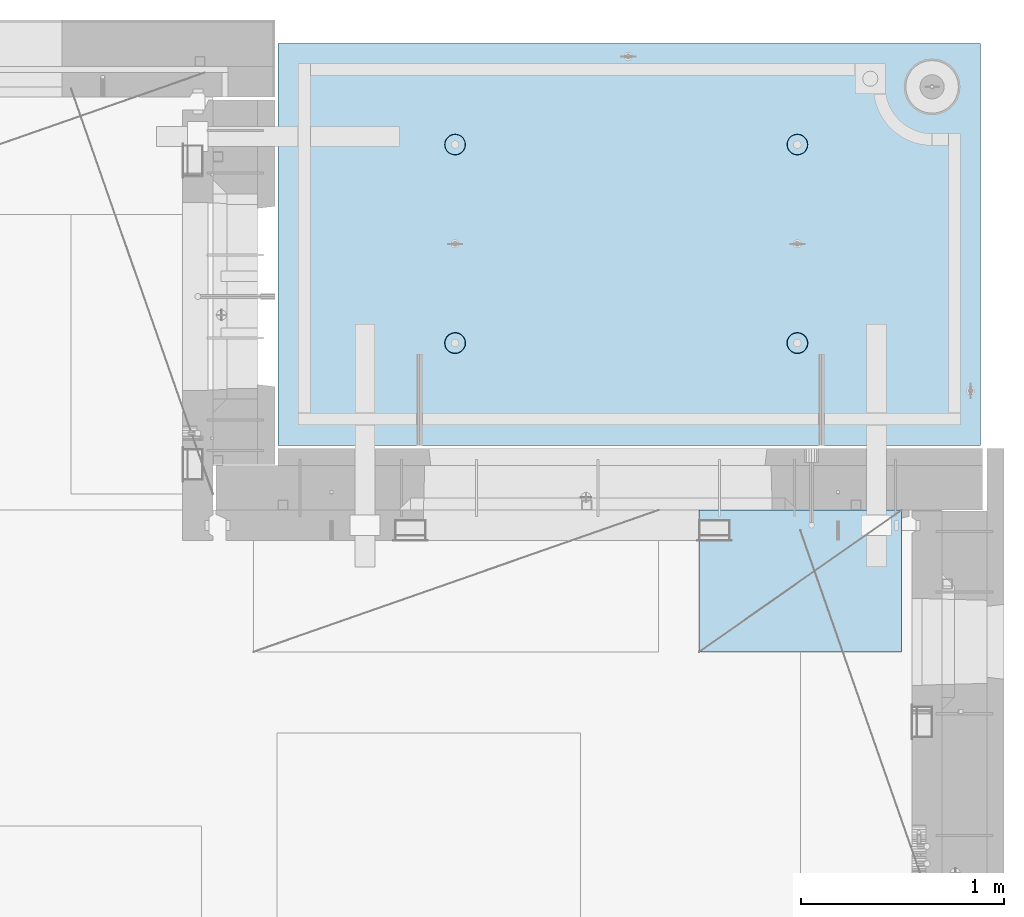
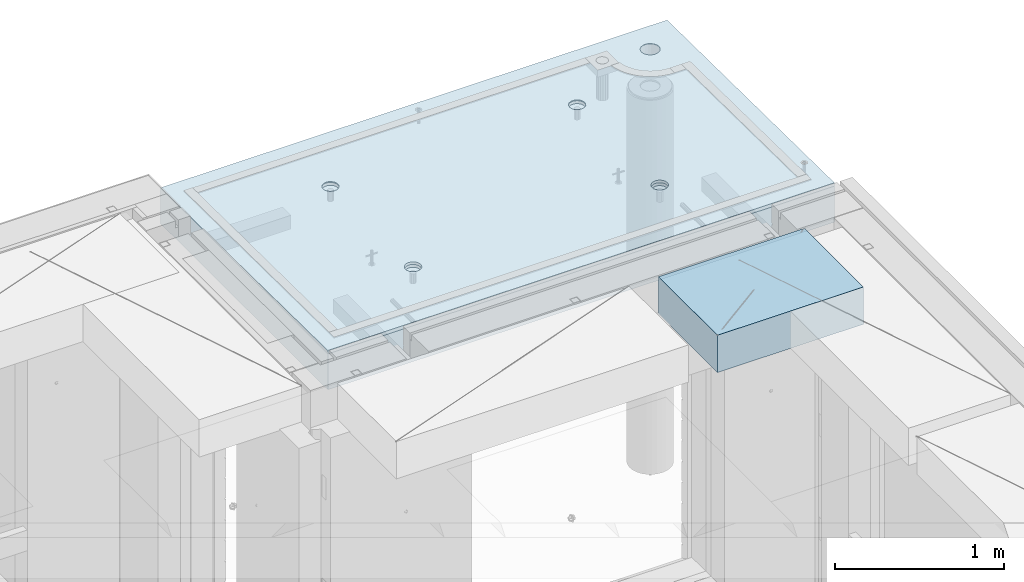
# One storey, part 202 of 334: 2 slabs, 1 plate, 2 elements without a shape of their own.
"""IFC2X3 building model written with IfcOpenShell, lengths in millimetres."""

from ifc_helpers import new_model, si_unit, frame, origin_with_axes, place, context, subcontext, project, spatial, faceted_brep, material, type_object, element, aggregate, save


model = new_model("IFC2X3")

# Units and contexts
model_context = context("Model", 3, precision=1e-05, world=origin_with_axes())
body_context = subcontext(model_context, "Body", "Model", "MODEL_VIEW")
ifc_project = project(units=[si_unit("LENGTHUNIT", "METRE", prefix="MILLI"), si_unit("AREAUNIT", "SQUARE_METRE"), si_unit("VOLUMEUNIT", "CUBIC_METRE"), si_unit("MASSUNIT", "GRAM", prefix="KILO"), si_unit("TIMEUNIT", "SECOND"), si_unit("PLANEANGLEUNIT", "RADIAN"), si_unit("SOLIDANGLEUNIT", "STERADIAN"), si_unit("THERMODYNAMICTEMPERATUREUNIT", "DEGREE_CELSIUS"), si_unit("LUMINOUSINTENSITYUNIT", "LUMEN")], contexts=[model_context])

# Site, building, storey
site_placement = place(None, origin_with_axes())
site = spatial("IfcSite", under=ifc_project, at=site_placement, CompositionType="ELEMENT")
building_placement = place(site_placement, origin_with_axes())
building = spatial("IfcBuilding", under=site, at=building_placement, CompositionType="ELEMENT")
storey_placement = place(building_placement, origin_with_axes())
storey = spatial("IfcBuildingStorey", under=building, at=storey_placement, Name="3", CompositionType="ELEMENT", Elevation=0.0)

# Assembly, slabs
assembly_1_placement = place(storey_placement, origin_with_axes())
assembly_1 = element("IfcElementAssembly", 1, at=assembly_1_placement, inside=storey, AssemblyPlace="NOTDEFINED", PredefinedType="REINFORCEMENT_UNIT")
ifc_material_1 = material(Name="CONCRETE/C35/45")
slab_type_1 = type_object("IfcSlabType", PredefinedType="NOTDEFINED")
slab_1_placement = place(assembly_1_placement, frame((31779.9998568133, 20899.9965573523, 90717.5), z_axis=(0.0, 1.0, 0.0), x_axis=(1.0, 0.0, 0.0)))
slab_1 = element("IfcSlab", 2, at=slab_1_placement, type_object=slab_type_1, material=ifc_material_1, PredefinedType="FLOOR", context=body_context, shape_type="Brep", body=[
    faceted_brep([(3287.06232936882, 9.55874156874779, 1751.46731182328), (3287.06232936882, 12.4999999999563, 1751.46731182328), (3278.5399580536, 12.4999999999563, 1734.74121634823), (3278.5399580536, 9.3480858430994, 1734.74121634823), (3265.26605352866, 12.4999999999563, 1721.46731182328), (3265.26605352866, 9.18090851265879, 1721.46731182328), (3248.5399580536, 12.4999999999563, 1712.94494050807), (3248.5399580536, 9.07357405936637, 1712.94494050807), (3229.99893839111, 12.4999999999563, 1710.00833148578), (3229.99893839111, 9.03658912732499, 1710.00833148578), (3211.45791872861, 12.4999999999563, 1712.94494050807), (3211.45791872861, 9.07357405936637, 1712.94494050807), (3194.73182325356, 12.4999999999563, 1721.46731182328), (3194.73182325356, 9.18090851267334, 1721.46731182328), (3181.45791872861, 12.4999999999563, 1734.74121634823), (3181.45791872861, 9.3480858430994, 1734.74121634823), (3172.9355474134, 12.4999999999563, 1751.46731182328), (3172.9355474134, 9.55874156874779, 1751.46731182328), (3169.99893839111, 12.4999999999563, 1770.00833148578), (3169.99893839111, 9.79225523948844, 1770.00833148578), (3172.9355474134, 12.4999999999563, 1788.54935114827), (3172.9355474134, 10.0257689102291, 1788.54935114827), (3181.45791872861, 12.4999999999563, 1805.27544662332), (3181.45791872861, 10.236424635892, 1805.27544662332), (3194.73182325356, 12.4999999999563, 1818.54935114827), (3194.73182325356, 10.4036019663181, 1818.54935114827), (3211.45791872861, 12.4999999999563, 1827.07172246349), (3211.45791872861, 10.5109364196105, 1827.07172246349), (3229.99893839111, 12.4999999999563, 1830.00833148578), (3229.99893839111, 10.5479213516664, 1830.00833148578), (3248.5399580536, 12.4999999999563, 1827.07172246349), (3248.5399580536, 10.5109364196105, 1827.07172246349), (3265.26605352866, 12.4999999999563, 1818.54935114827), (3265.26605352866, 10.4036019663181, 1818.54935114827), (3278.5399580536, 12.4999999999563, 1805.27544662332), (3278.5399580536, 10.2364246358775, 1805.27544662332), (3287.06232936882, 12.4999999999563, 1788.54935114827), (3287.06232936882, 10.0257689102291, 1788.54935114827), (3289.99893839111, 12.4999999999563, 1770.00833148578), (3289.99893839111, 9.79225523948844, 1770.00833148578), (7.41420080885291e-08, 12.4999999999927, 0.0), (-7.41420080885291e-08, -12.5, -3.63797880709171e-12), (0.0, 12.5, 1985.00366210938), (3470.0, 12.5, 0.0), (3470.00000000004, 12.4999999999563, 1985.00366210935), (3470.0, -12.5, 0.0), (2614.71871715545, -5.93617388149141, 521.168755308547), (2613.67503600632, 12.4999999999709, 520.829642746605), (2616.18047624359, 12.4999999999709, 505.010915653602), (2617.28998057371, -6.13967274603783, 505.010915653602), (2607.28293696061, -5.7526757610467, 535.738532951145), (2606.40396524136, 12.4999999999709, 535.099922616191), (2595.7125242481, -5.60710538028798, 547.296842506817), (2595.0790070157, 12.4999999999709, 546.424880841845), (2581.14006820649, -5.51366887726181, 554.715714533479), (2580.80872714612, 12.4999999999709, 553.695951606805), (2564.99000005311, -5.48147745869937, 557.271717883286), (2564.99000005311, 12.4999999999709, 556.201391844079), (2548.83993189974, -5.51366887726181, 554.715714533479), (2549.17127296011, 12.4999999999709, 553.695951606805), (2534.26747585813, -5.60710538028798, 547.296842506817), (2534.90099309052, 12.4999999999709, 546.424880841845), (2522.69706314561, -5.75267576103215, 535.738532951145), (2523.57603486487, 12.4999999999709, 535.099922616191), (2515.26128295077, -5.93617388147686, 521.168755308547), (2516.30496409991, 12.4999999999709, 520.829642746605), (2512.69001953251, -6.13967274603783, 505.010915653602), (2513.79952386263, 12.4999999999709, 505.010915653602), (2515.23823726424, -6.34326591769059, 488.84558800119), (2516.30496409991, 12.4999999999709, 489.192188560599), (2522.65977443627, -6.52701093736687, 474.256206522903), (2523.57603486487, 12.4999999999709, 474.921908691009), (2534.2301871423, -6.67288650246337, 462.673665286093), (2534.90099309052, 12.4999999999709, 463.596950465359), (2548.81688620273, -6.76656990486663, 455.235189411429), (2549.17127296011, 12.4999999999709, 456.325879700398), (2564.99000005311, -6.79885563062271, 452.67169805654), (2564.99000005311, 12.4999999999709, 453.820439463125), (2581.16311390349, -6.76656990486663, 455.235189411429), (2580.80872714612, 12.4999999999709, 456.325879700398), (2595.74981296392, -6.67288650246337, 462.673665286093), (2595.07900701571, 12.4999999999709, 463.596950465359), (2607.32022566996, -6.52701093736687, 474.256206522903), (2606.40396524136, 12.4999999999709, 474.921908691009), (2614.74176284199, -6.34326591769059, 488.84558800119), (2613.67503600632, 12.4999999999709, 489.192188560599), (924.718717121814, -5.93617388307757, 521.168755181017), (923.675035972585, 12.4999999999854, 520.829642619046), (926.180476209858, 12.4999999999854, 505.010915526043), (927.289980540074, -6.13967274762399, 505.010915526043), (917.282936926953, -5.75267576263286, 535.738532823641), (916.403965207624, 12.4999999999854, 535.099922488633), (905.712524214421, -5.60710538187413, 547.296842379335), (905.07900698197, 12.4999999999854, 546.424880714287), (891.140068172776, -5.51366887886252, 554.715714406011), (890.808727112384, 12.4999999999854, 553.695951479247), (874.990000019381, -5.48147746030008, 557.271717755822), (874.990000019381, 12.4999999999854, 556.20139171652), (858.839931865987, -5.51366887886252, 554.715714406011), (859.171272926378, 12.4999999999854, 553.695951479247), (844.267475824341, -5.60710538187413, 547.296842379335), (844.900993056792, 12.4999999999854, 546.424880714287), (832.697063111809, -5.75267576263286, 535.738532823641), (833.576034831138, 12.4999999999854, 535.099922488633), (825.261282916948, -5.93617388307757, 521.168755181017), (826.304964066177, 12.4999999999854, 520.829642619046), (822.690019498688, -6.13967274762399, 505.010915526043), (823.799523828904, 12.4999999999854, 505.010915526043), (825.238237230413, -6.34326591927675, 488.845587873602), (826.304964066174, 12.4999999999854, 489.19218843304), (832.659774402466, -6.52701093895303, 474.25620639529), (833.576034831141, 12.4999999999854, 474.921908563454), (844.230187108518, -6.67288650404953, 462.673665158458), (844.900993056788, 12.4999999999854, 463.5969503378), (858.816886168974, -6.76656990646734, 455.23518928378), (859.171272926378, 12.4999999999854, 456.32587957284), (874.990000019381, -6.79885563222342, 452.671697928887), (874.990000019381, 12.4999999999854, 453.820439335566), (891.163113869789, -6.76656990646734, 455.23518928378), (890.808727112384, 12.4999999999854, 456.32587957284), (905.749812930244, -6.67288650404953, 462.673665158458), (905.079006981974, 12.4999999999854, 463.5969503378), (917.320225636297, -6.52701093895303, 474.25620639529), (916.403965207621, 12.4999999999854, 474.921908563454), (924.741762808349, -6.34326591927675, 488.845587873602), (923.675035972588, 12.4999999999854, 489.19218843304), (924.02016693788, 6.4034111394576, 1500.93361352766), (923.67503595199, 12.4999999999854, 1500.82147367257), (926.18047618926, 12.4999999999854, 1485.00274657956), (926.555311256641, 6.20277086795249, 1485.00274657956), (916.688838773403, 6.58433162167785, 1515.29872631776), (916.403965187026, 12.4999999999854, 1515.09175354215), (905.280958178348, 6.7278571434581, 1526.69467377167), (905.079006961372, 12.4999999999854, 1526.4167117678), (890.913204613287, 6.81998112349538, 1534.0093312807), (890.808727091786, 12.4999999999854, 1533.68778253277), (874.989999998783, 6.85172034216521, 1536.52942989253), (874.989999998783, 12.4999999999854, 1536.19322277004), (859.066795384279, 6.81998112349538, 1534.0093312807), (859.17127290578, 12.4999999999854, 1533.68778253277), (844.699041819218, 6.7278571434581, 1526.69467377167), (844.900993036194, 12.4999999999854, 1526.4167117678), (833.291161224162, 6.58433162167785, 1515.29872631776), (833.57603481054, 12.4999999999854, 1515.09175354215), (825.959833059685, 6.4034111394576, 1500.93361352766), (826.304964045576, 12.4999999999854, 1500.82147367257), (823.424688740924, 6.20277086795249, 1485.00274657956), (823.799523808306, 12.4999999999854, 1485.00274657956), (825.93711110095, 6.00203761411831, 1469.06449681953), (826.304964045576, 12.4999999999854, 1469.18401948656), (833.254396317472, 5.82087370089721, 1454.68005557312), (833.57603481054, 12.4999999999854, 1454.91373961698), (844.66227690614, 5.67704728177341, 1443.26021682579), (844.90099303619, 12.4999999999854, 1443.58878139132), (859.044073415214, 5.58467987058975, 1435.9262308483), (859.17127290578, 12.4999999999854, 1436.31771062636), (874.989999998783, 5.55284766948898, 1433.39874941703), (874.989999998783, 12.4999999999854, 1433.81227038909), (890.935926582351, 5.58467987058975, 1435.9262308483), (890.808727091786, 12.4999999999854, 1436.31771062636), (905.317723091426, 5.67704728177341, 1443.26021682579), (905.079006961376, 12.4999999999854, 1443.58878139132), (916.725603680094, 5.82087370089721, 1454.68005557312), (916.403965187026, 12.4999999999854, 1454.91373961698), (924.042888896616, 6.00203761411831, 1469.06449681953), (923.67503595199, 12.4999999999854, 1469.18401948656), (2564.9899999698, 12.4999999999709, 1433.81227048016), (2564.9899999698, 5.55284767062403, 1433.39874950818), (2580.93592655335, 5.5846798717248, 1435.92623093945), (2580.8087270628, 12.4999999999709, 1436.31771071744), (2549.17127287679, 12.4999999999709, 1436.31771071744), (2549.04407338624, 5.5846798717248, 1435.92623093945), (2534.9009930072, 12.4999999999709, 1443.5887814824), (2534.66227687719, 5.67704728290846, 1443.26021691693), (2523.57603478155, 12.4999999999709, 1454.91373970805), (2523.25439628854, 5.82087370203226, 1454.68005566423), (2516.30496401659, 12.4999999999709, 1469.18401957764), (2515.93711107203, 6.00203761523881, 1469.06449691063), (2513.79952377931, 12.4999999999709, 1485.00274667064), (2513.424688712, 6.20277086908754, 1485.00274667064), (2516.30496401659, 12.4999999999709, 1500.82147376364), (2515.95983303076, 6.40341114059265, 1500.93361361872), (2523.57603478155, 12.4999999999709, 1515.09175363323), (2523.29116119523, 6.5843316228129, 1515.2987264088), (2534.90099300721, 12.4999999999709, 1526.41671185888), (2534.69904179027, 6.72785714459314, 1526.69467386269), (2549.17127287679, 12.4999999999709, 1533.68778262385), (2549.06679535531, 6.81998112463043, 1534.00933137171), (2564.9899999698, 12.4999999999709, 1536.19322286112), (2564.9899999698, 6.85172034330026, 1536.52942998354), (2580.8087270628, 12.4999999999709, 1533.68778262385), (2580.91320458428, 6.81998112463043, 1534.00933137171), (2595.07900693238, 12.4999999999709, 1526.41671185888), (2595.28095814932, 6.72785714459314, 1526.69467386269), (2606.40396515804, 12.4999999999709, 1515.09175363323), (2606.68883874436, 6.5843316228129, 1515.2987264088), (2613.675035923, 12.4999999999709, 1500.82147376364), (2614.02016690883, 6.40341114059265, 1500.93361361872), (2606.72560365105, 5.82087370203226, 1454.68005566423), (2595.3177230624, 5.67704728290846, 1443.26021691693), (2616.55531122759, 6.20277086908754, 1485.00274667064), (2614.04288886756, 6.00203761523881, 1469.06449691063), (2595.07900693239, 12.4999999999709, 1443.5887814824), (2606.40396515804, 12.4999999999709, 1454.91373970805), (2613.675035923, 12.4999999999709, 1469.18401957764), (2616.18047616028, 12.4999999999709, 1485.00274667064)], [[[0, 1, 2, 3]], [[3, 2, 4, 5]], [[5, 4, 6, 7]], [[7, 6, 8, 9]], [[9, 8, 10, 11]], [[11, 10, 12, 13]], [[13, 12, 14, 15]], [[15, 14, 16, 17]], [[17, 16, 18, 19]], [[19, 18, 20, 21]], [[21, 20, 22, 23]], [[23, 22, 24, 25]], [[25, 24, 26, 27]], [[27, 26, 28, 29]], [[29, 28, 30, 31]], [[31, 30, 32, 33]], [[33, 32, 34, 35]], [[35, 34, 36, 37]], [[37, 36, 38, 39]], [[39, 38, 1, 0]], [[40, 41, 42]], [[43, 44, 45]], [[40, 43, 45, 41]], [[46, 47, 48, 49]], [[50, 51, 47, 46]], [[52, 53, 51, 50]], [[54, 55, 53, 52]], [[56, 57, 55, 54]], [[58, 59, 57, 56]], [[59, 58, 60, 61]], [[61, 60, 62, 63]], [[63, 62, 64, 65]], [[65, 64, 66, 67]], [[67, 66, 68, 69]], [[69, 68, 70, 71]], [[71, 70, 72, 73]], [[73, 72, 74, 75]], [[75, 74, 76, 77]], [[78, 79, 77, 76]], [[80, 81, 79, 78]], [[82, 83, 81, 80]], [[84, 85, 83, 82]], [[49, 48, 85, 84]], [[86, 87, 88, 89]], [[90, 91, 87, 86]], [[92, 93, 91, 90]], [[94, 95, 93, 92]], [[96, 97, 95, 94]], [[98, 99, 97, 96]], [[99, 98, 100, 101]], [[101, 100, 102, 103]], [[103, 102, 104, 105]], [[105, 104, 106, 107]], [[107, 106, 108, 109]], [[109, 108, 110, 111]], [[111, 110, 112, 113]], [[113, 112, 114, 115]], [[115, 114, 116, 117]], [[118, 119, 117, 116]], [[120, 121, 119, 118]], [[122, 123, 121, 120]], [[124, 125, 123, 122]], [[89, 88, 125, 124]], [[126, 127, 128, 129]], [[130, 131, 127, 126]], [[132, 133, 131, 130]], [[134, 135, 133, 132]], [[136, 137, 135, 134]], [[138, 139, 137, 136]], [[140, 141, 139, 138]], [[142, 143, 141, 140]], [[143, 142, 144, 145]], [[145, 144, 146, 147]], [[147, 146, 148, 149]], [[149, 148, 150, 151]], [[151, 150, 152, 153]], [[153, 152, 154, 155]], [[155, 154, 156, 157]], [[157, 156, 158, 159]], [[159, 158, 160, 161]], [[162, 163, 161, 160]], [[164, 165, 163, 162]], [[129, 128, 165, 164]], [[166, 167, 168, 169]], [[170, 171, 167, 166]], [[172, 173, 171, 170]], [[174, 175, 173, 172]], [[176, 177, 175, 174]], [[178, 179, 177, 176]], [[180, 181, 179, 178]], [[182, 183, 181, 180]], [[183, 182, 184, 185]], [[185, 184, 186, 187]], [[187, 186, 188, 189]], [[189, 188, 190, 191]], [[191, 190, 192, 193]], [[193, 192, 194, 195]], [[195, 194, 196, 197]], [[44, 42, 41, 45], [3, 5, 7, 9, 11, 13, 15, 17, 19, 21, 23, 25, 27, 29, 31, 33, 35, 37, 39, 0], [198, 199, 168, 167, 171, 173, 175, 177, 179, 181, 183, 185, 187, 189, 191, 193, 195, 197, 200, 201], [162, 160, 158, 156, 154, 152, 150, 148, 146, 144, 142, 140, 138, 136, 134, 132, 130, 126, 129, 164], [122, 120, 118, 116, 114, 112, 110, 108, 106, 104, 102, 100, 98, 96, 94, 92, 90, 86, 89, 124], [82, 80, 78, 76, 74, 72, 70, 68, 66, 64, 62, 60, 58, 56, 54, 52, 50, 46, 49, 84]], [[169, 168, 199, 202]], [[198, 203, 202, 199]], [[201, 204, 203, 198]], [[200, 205, 204, 201]], [[197, 196, 205, 200]], [[43, 40, 42, 44], [34, 32, 30, 28, 26, 24, 22, 20, 18, 16, 14, 12, 10, 8, 6, 4, 2, 1, 38, 36], [194, 192, 190, 188, 186, 184, 182, 180, 178, 176, 174, 172, 170, 166, 169, 202, 203, 204, 205, 196], [131, 133, 135, 137, 139, 141, 143, 145, 147, 149, 151, 153, 155, 157, 159, 161, 163, 165, 128, 127], [91, 93, 95, 97, 99, 101, 103, 105, 107, 109, 111, 113, 115, 117, 119, 121, 123, 125, 88, 87], [51, 53, 55, 57, 59, 61, 63, 65, 67, 69, 71, 73, 75, 77, 79, 81, 83, 85, 48, 47]]]),
])
slab_type_2 = type_object("IfcSlabType", PredefinedType="NOTDEFINED")
slab_2_placement = place(assembly_1_placement, frame((31779.9998568132, 20899.9965573523, 90575.0), z_axis=(-1.19799915409591e-06, 0.999999999999282, 0.0), x_axis=(0.999999999999282, 1.19800000174933e-06, 0.0)))
slab_2 = element("IfcSlab", 3, at=slab_2_placement, type_object=slab_type_2, material=ifc_material_1, PredefinedType="FLOOR", context=body_context, shape_type="Brep", body=[
    faceted_brep([(2959.65048069304, -130.0, 1795.81551698422), (2959.65048069304, 130.000000000015, 1795.81551698422), (2951.52269537287, 130.000000000015, 1783.6488444481), (2951.52269537287, -130.0, 1783.6488444481), (2939.35761686434, 130.000000000015, 1775.51867349706), (2939.35761686434, -130.0, 1775.51867349706), (2925.00726809365, 130.000000000015, 1772.66274895821), (2925.00726809365, -130.0, 1772.66274895821), (2910.65635957491, 130.000000000015, 1775.51585945357), (2910.65635957491, -130.0, 1775.51585945357), (2898.48968703879, 130.000000000015, 1783.64364477374), (2898.48968703879, -130.0, 1783.64364477374), (2890.35951608775, 130.000000000015, 1795.80872328227), (2890.35951608775, -130.0, 1795.80872328227), (2887.5035915489, 130.000000000015, 1810.15907205296), (2887.5035915489, -130.0, 1810.15907205296), (2890.35670204427, 130.000000000015, 1824.5099805717), (2890.35670204427, -130.0, 1824.5099805717), (2898.48448736444, 130.000000000015, 1836.67665310783), (2898.48448736444, -130.0, 1836.67665310783), (2910.64956587296, 130.000000000015, 1844.80682405887), (2910.64956587296, -130.0, 1844.80682405887), (2924.99991464366, 130.000000000015, 1847.66274859772), (2924.99991464366, -130.0, 1847.66274859772), (2939.3508231624, 130.000000000015, 1844.80963810235), (2939.3508231624, -130.0, 1844.80963810235), (2951.51749569851, 130.000000000015, 1836.68185278219), (2951.51749569851, -130.0, 1836.68185278219), (2959.64766664955, 130.000000000015, 1824.51677427365), (2959.64766664955, -130.0, 1824.51677427365), (2962.50359118841, 130.000000000015, 1810.16642550296), (2962.50359118841, -130.0, 1810.16642550296), (3470.0, -130.0, -2.20097717829049e-09), (0.0, -130.0, -3.63797880709171e-12), (0.0, 130.0, -1.81898940354586e-12), (3470.0, 130.0, -2.20097717829049e-09), (3470.00048828125, -130.0, 1985.00366210938), (3470.00048828125, 130.0, 1985.00366210938), (0.000559809086553287, -130.0, 1985.00366210938), (0.000559809086553287, 130.0, 1985.00366210938), (890.443701616427, -110.0, 1437.44815412734), (904.382128602592, -110.0, 1444.55010256952), (915.443737652884, -110.0, 1455.61166772744), (922.54574140269, -110.0, 1469.55006653296), (924.992946242415, -110.0, 1485.00091139648), (922.545802711662, -110.0, 1500.4517659704), (915.443854269477, -110.0, 1514.39019295657), (904.382289111563, -110.0, 1525.45180200686), (890.44389030604, -110.0, 1532.55380575666), (874.993045442512, -110.0, 1535.00101059639), (859.5421908686, -110.0, 1532.55386706564), (845.603763882435, -110.0, 1525.45191862345), (834.542154832139, -110.0, 1514.39035346554), (827.440151082337, -110.0, 1500.45195466001), (824.992946242612, -110.0, 1485.00110979649), (827.440089773365, -110.0, 1469.55025522257), (834.542038215546, -110.0, 1455.61182823641), (845.603603373464, -110.0, 1444.55021918611), (859.542002178987, -110.0, 1437.44821543631), (874.992847042511, -110.0, 1435.00101059658), (923.678013579975, -130.0, 1500.81964109834), (926.183422432889, -130.0, 1485.00090903458), (916.406971127264, -130.0, 1515.08993539371), (905.082035370349, -130.0, 1526.41491608806), (890.811769926597, -130.0, 1533.68601516524), (874.993047804415, -130.0, 1536.19148678686), (859.174315740653, -130.0, 1533.68607793395), (844.904021445287, -130.0, 1526.41503548124), (833.579040750941, -130.0, 1515.09009972432), (826.307941673756, -130.0, 1500.81983428057), (823.802470052138, -130.0, 1485.00111215839), (826.307878905049, -130.0, 1469.18238009463), (833.578921357763, -130.0, 1454.91208579926), (844.903857114674, -130.0, 1443.58710510491), (859.17412255843, -130.0, 1436.31600602773), (874.992844680608, -130.0, 1433.81053440611), (890.811576744374, -130.0, 1436.31594325902), (905.081871039736, -130.0, 1443.58698571173), (916.406851734086, -130.0, 1454.91192146865), (923.677950811267, -130.0, 1469.1821869124), (890.441757333232, -110.0, 457.456323075745), (904.380184319398, -110.0, 464.558271517926), (915.44179336969, -110.0, 475.619836675844), (922.543797119495, -110.0, 489.558235481371), (924.991001959221, -110.0, 505.009080344891), (922.543858428468, -110.0, 520.459934918807), (915.441909986286, -110.0, 534.398361904972), (904.380344828369, -110.0, 545.459970955264), (890.441946022846, -110.0, 552.56197470507), (874.991101159318, -110.0, 555.009179544795), (859.540246585406, -110.0, 552.562036014042), (845.60181959924, -110.0, 545.460087571857), (834.540210548948, -110.0, 534.398522413943), (827.438206799143, -110.0, 520.46012360842), (824.991001959417, -110.0, 505.009278744892), (827.43814549017, -110.0, 489.558424170984), (834.540093932352, -110.0, 475.619997184815), (845.601659090269, -110.0, 464.558388134519), (859.540057895792, -110.0, 457.456384384717), (874.99090275932, -110.0, 455.009179544992), (923.676069296784, -130.0, 520.827810046754), (926.181478149694, -130.0, 505.009077982988), (916.405026844073, -130.0, 535.098104342116), (905.080091087159, -130.0, 546.423085036466), (890.809825643402, -130.0, 553.694184113647), (874.991103521224, -130.0, 556.199655735272), (859.172371457458, -130.0, 553.694246882354), (844.902077162096, -130.0, 546.423204429644), (833.57709646775, -130.0, 535.098268672729), (826.305997390566, -130.0, 520.828003228977), (823.800525768944, -130.0, 505.009281106795), (826.305934621854, -130.0, 489.190549043033), (833.576977074568, -130.0, 474.920254747667), (844.901912831479, -130.0, 463.595274053321), (859.172178275239, -130.0, 456.32417497614), (874.990900397414, -130.0, 453.818703354518), (890.809632461183, -130.0, 456.324112207432), (905.079926756542, -130.0, 463.595154660143), (916.404907450891, -130.0, 474.920090417054), (923.676006528072, -130.0, 489.19035586081), (2580.44175736364, -110.0, 457.452970243303), (2594.3801843498, -110.0, 464.554918685484), (2605.4417934001, -110.0, 475.616483843402), (2612.54379714991, -110.0, 489.554882648928), (2614.99100198962, -110.0, 505.005727512449), (2612.54385845887, -110.0, 520.456582086365), (2605.44191001669, -110.0, 534.39500907253), (2594.38034485878, -110.0, 545.456618122822), (2580.44194605325, -110.0, 552.558621872628), (2564.99110118972, -110.0, 555.005826712353), (2549.54024661581, -110.0, 552.5586831816), (2535.60181962965, -110.0, 545.456734739415), (2524.54021057935, -110.0, 534.395169581501), (2517.43820682954, -110.0, 520.456770775978), (2514.99100198982, -110.0, 505.00592591245), (2517.43814552058, -110.0, 489.555071338542), (2524.54009396276, -110.0, 475.616644352373), (2535.60165912067, -110.0, 464.555035302077), (2549.5400579262, -110.0, 457.453031552275), (2564.99090278973, -110.0, 455.00582671255), (2613.67606932719, -130.0, 520.824457214312), (2616.1814781801, -130.0, 505.005725150546), (2606.40502687448, -130.0, 535.094751509674), (2595.08009111756, -130.0, 546.419732204024), (2580.80982567381, -130.0, 553.690831281205), (2564.99110355163, -130.0, 556.19630290283), (2549.17237148786, -130.0, 553.690894049912), (2534.9020771925, -130.0, 546.419851597202), (2523.57709649815, -130.0, 535.094915840287), (2516.30599742097, -130.0, 520.824650396535), (2513.80052579935, -130.0, 505.005928274353), (2516.30593465226, -130.0, 489.187196210591), (2523.57697710497, -130.0, 474.916901915225), (2534.90191286189, -130.0, 463.591921220879), (2549.17217830564, -130.0, 456.320822143698), (2564.99090042782, -130.0, 453.815350522076), (2580.80963249159, -130.0, 456.32075937499), (2595.07992678695, -130.0, 463.591801827701), (2606.4049074813, -130.0, 474.916737584612), (2613.67600655848, -130.0, 489.187003028368), (2580.44370158411, -110.0, 1437.44480125841), (2594.38212857028, -110.0, 1444.5467497006), (2605.44373762057, -110.0, 1455.60831485851), (2612.54574137038, -110.0, 1469.54671366404), (2614.9929462101, -110.0, 1484.99755852756), (2612.54580267935, -110.0, 1500.44841310148), (2605.44385423717, -110.0, 1514.38684008764), (2594.38228907925, -110.0, 1525.44844913793), (2580.44389027373, -110.0, 1532.55045288774), (2564.9930454102, -110.0, 1534.99765772746), (2549.54219083629, -110.0, 1532.55051419671), (2535.60376385012, -110.0, 1525.44856575453), (2524.54215479983, -110.0, 1514.38700059661), (2517.44015105002, -110.0, 1500.44860179109), (2514.99294621029, -110.0, 1484.99775692756), (2517.44008974105, -110.0, 1469.54690235365), (2524.54203818323, -110.0, 1455.60847536748), (2535.60360334115, -110.0, 1444.54686631719), (2549.54200214667, -110.0, 1437.44486256739), (2564.9928470102, -110.0, 1434.99765772766), (2613.67801354766, -130.0, 1500.81628822942), (2616.18342240057, -130.0, 1484.99755616566), (2606.40697109495, -130.0, 1515.08658252479), (2595.08203533804, -130.0, 1526.41156321914), (2580.81176989429, -130.0, 1533.68266229632), (2564.9930477721, -130.0, 1536.18813391794), (2549.17431570834, -130.0, 1533.68272506502), (2534.90402141297, -130.0, 1526.41168261231), (2523.57904071863, -130.0, 1515.0867468554), (2516.30794164144, -130.0, 1500.81648141164), (2513.80247001983, -130.0, 1484.99775928947), (2516.30787887274, -130.0, 1469.1790272257), (2523.57892132545, -130.0, 1454.90873293034), (2534.90385708237, -130.0, 1443.58375223599), (2549.17412252611, -130.0, 1436.31265315881), (2564.99284464829, -130.0, 1433.80718153719), (2580.81157671207, -130.0, 1436.3125903901), (2595.08187100743, -130.0, 1443.58363284281), (2606.40685170178, -130.0, 1454.90856859972), (2613.67795077896, -130.0, 1469.17883404348), (3278.54339977372, -130.0, 1734.73471172154), (3265.26946891338, -130.0, 1721.46083353204), (3248.54335652997, -130.0, 1712.93849540142), (3230.00233104128, -130.0, 1710.00192316452), (3211.46131720506, -130.0, 1712.93856897219), (3194.73523863843, -130.0, 1721.46097347196), (3181.46136044892, -130.0, 1734.73490433231), (3172.9390223183, -130.0, 1751.46101671571), (3170.0024500814, -130.0, 1770.0020422044), (3172.93909588907, -130.0, 1788.54305604063), (3181.46150038884, -130.0, 1805.26913460726), (3194.73543124919, -130.0, 1818.54301279676), (3211.46154363259, -130.0, 1827.06535092738), (3230.00256912128, -130.0, 1830.00192316428), (3248.54358295751, -130.0, 1827.06527735662), (3265.26966152415, -130.0, 1818.54287285685), (3278.54353971364, -130.0, 1805.2689419965), (3287.06587784427, -130.0, 1788.5428296131), (3290.00245008117, -130.0, 1770.0018041244), (3287.0658042735, -130.0, 1751.46079028817), (3278.54353971364, 130.0, 1805.2689419965), (3287.06587784427, 130.0, 1788.5428296131), (3265.26966152415, 130.0, 1818.54287285685), (3248.54358295751, 130.0, 1827.06527735662), (3230.00256912128, 130.0, 1830.00192316428), (3211.46154363259, 130.0, 1827.06535092738), (3194.73543124919, 130.0, 1818.54301279676), (3181.46150038884, 130.0, 1805.26913460726), (3172.93909588907, 130.0, 1788.54305604063), (3170.0024500814, 130.0, 1770.0020422044), (3172.9390223183, 130.0, 1751.46101671571), (3181.46136044892, 130.0, 1734.73490433231), (3194.73523863843, 130.0, 1721.46097347196), (3211.46131720506, 130.0, 1712.93856897219), (3230.00233104128, 130.0, 1710.00192316452), (3248.54335652997, 130.0, 1712.93849540142), (3265.26946891338, 130.0, 1721.46083353204), (3278.54339977372, 130.0, 1734.73471172154), (3287.0658042735, 130.0, 1751.46079028817), (3290.00245008117, 130.0, 1770.0018041244)], [[[0, 1, 2, 3]], [[3, 2, 4, 5]], [[5, 4, 6, 7]], [[7, 6, 8, 9]], [[9, 8, 10, 11]], [[11, 10, 12, 13]], [[13, 12, 14, 15]], [[15, 14, 16, 17]], [[17, 16, 18, 19]], [[19, 18, 20, 21]], [[21, 20, 22, 23]], [[23, 22, 24, 25]], [[25, 24, 26, 27]], [[27, 26, 28, 29]], [[29, 28, 30, 31]], [[31, 30, 1, 0]], [[32, 33, 34, 35]], [[36, 32, 35, 37]], [[38, 36, 37, 39]], [[33, 38, 39, 34]], [[40, 41, 42, 43, 44, 45, 46, 47, 48, 49, 50, 51, 52, 53, 54, 55, 56, 57, 58, 59]], [[60, 45, 44, 61]], [[62, 46, 45, 60]], [[63, 47, 46, 62]], [[64, 48, 47, 63]], [[65, 49, 48, 64]], [[66, 50, 49, 65]], [[67, 51, 50, 66]], [[68, 52, 51, 67]], [[69, 53, 52, 68]], [[70, 54, 53, 69]], [[71, 55, 54, 70]], [[72, 56, 55, 71]], [[73, 57, 56, 72]], [[74, 58, 57, 73]], [[75, 59, 58, 74]], [[76, 40, 59, 75]], [[77, 41, 40, 76]], [[78, 42, 41, 77]], [[79, 43, 42, 78]], [[61, 44, 43, 79]], [[80, 81, 82, 83, 84, 85, 86, 87, 88, 89, 90, 91, 92, 93, 94, 95, 96, 97, 98, 99]], [[100, 85, 84, 101]], [[102, 86, 85, 100]], [[103, 87, 86, 102]], [[104, 88, 87, 103]], [[105, 89, 88, 104]], [[106, 90, 89, 105]], [[107, 91, 90, 106]], [[108, 92, 91, 107]], [[109, 93, 92, 108]], [[110, 94, 93, 109]], [[111, 95, 94, 110]], [[112, 96, 95, 111]], [[113, 97, 96, 112]], [[114, 98, 97, 113]], [[115, 99, 98, 114]], [[116, 80, 99, 115]], [[117, 81, 80, 116]], [[118, 82, 81, 117]], [[119, 83, 82, 118]], [[101, 84, 83, 119]], [[120, 121, 122, 123, 124, 125, 126, 127, 128, 129, 130, 131, 132, 133, 134, 135, 136, 137, 138, 139]], [[140, 125, 124, 141]], [[142, 126, 125, 140]], [[143, 127, 126, 142]], [[144, 128, 127, 143]], [[145, 129, 128, 144]], [[146, 130, 129, 145]], [[147, 131, 130, 146]], [[148, 132, 131, 147]], [[149, 133, 132, 148]], [[150, 134, 133, 149]], [[151, 135, 134, 150]], [[152, 136, 135, 151]], [[153, 137, 136, 152]], [[154, 138, 137, 153]], [[155, 139, 138, 154]], [[156, 120, 139, 155]], [[157, 121, 120, 156]], [[158, 122, 121, 157]], [[159, 123, 122, 158]], [[141, 124, 123, 159]], [[160, 161, 162, 163, 164, 165, 166, 167, 168, 169, 170, 171, 172, 173, 174, 175, 176, 177, 178, 179]], [[180, 165, 164, 181]], [[182, 166, 165, 180]], [[183, 167, 166, 182]], [[184, 168, 167, 183]], [[185, 169, 168, 184]], [[186, 170, 169, 185]], [[187, 171, 170, 186]], [[188, 172, 171, 187]], [[189, 173, 172, 188]], [[190, 174, 173, 189]], [[191, 175, 174, 190]], [[192, 176, 175, 191]], [[193, 177, 176, 192]], [[194, 178, 177, 193]], [[195, 179, 178, 194]], [[196, 160, 179, 195]], [[197, 161, 160, 196]], [[198, 162, 161, 197]], [[199, 163, 162, 198]], [[181, 164, 163, 199]], [[32, 36, 38, 33], [3, 5, 7, 9, 11, 13, 15, 17, 19, 21, 23, 25, 27, 29, 31, 0], [198, 197, 196, 195, 194, 193, 192, 191, 190, 189, 188, 187, 186, 185, 184, 183, 182, 180, 181, 199], [158, 157, 156, 155, 154, 153, 152, 151, 150, 149, 148, 147, 146, 145, 144, 143, 142, 140, 141, 159], [118, 117, 116, 115, 114, 113, 112, 111, 110, 109, 108, 107, 106, 105, 104, 103, 102, 100, 101, 119], [78, 77, 76, 75, 74, 73, 72, 71, 70, 69, 68, 67, 66, 65, 64, 63, 62, 60, 61, 79], [200, 201, 202, 203, 204, 205, 206, 207, 208, 209, 210, 211, 212, 213, 214, 215, 216, 217, 218, 219]], [[216, 220, 221, 217]], [[215, 222, 220, 216]], [[214, 223, 222, 215]], [[213, 224, 223, 214]], [[212, 225, 224, 213]], [[211, 226, 225, 212]], [[210, 227, 226, 211]], [[209, 228, 227, 210]], [[208, 229, 228, 209]], [[207, 230, 229, 208]], [[206, 231, 230, 207]], [[205, 232, 231, 206]], [[204, 233, 232, 205]], [[203, 234, 233, 204]], [[202, 235, 234, 203]], [[201, 236, 235, 202]], [[200, 237, 236, 201]], [[219, 238, 237, 200]], [[218, 239, 238, 219]], [[217, 221, 239, 218]], [[37, 35, 34, 39], [26, 24, 22, 20, 18, 16, 14, 12, 10, 8, 6, 4, 2, 1, 30, 28], [220, 222, 223, 224, 225, 226, 227, 228, 229, 230, 231, 232, 233, 234, 235, 236, 237, 238, 239, 221]]]),
])
aggregate(assembly_1, [slab_1, slab_2])

# Assembly, plate
assembly_2_placement = place(storey_placement, origin_with_axes())
assembly_2 = element("IfcElementAssembly", 4, at=assembly_2_placement, inside=storey, Name="Steel Assembly", AssemblyPlace="NOTDEFINED", PredefinedType="NOTDEFINED")
ifc_material_2 = material()
plate_type = type_object("IfcPlateType", PredefinedType="NOTDEFINED")
plate_placement = place(assembly_2_placement, frame((34860.0, 20580.0000000707, 90595.3), z_axis=(0.0, -1.0, 0.0), x_axis=(-1.0, 3.00000001838171e-08, 0.0)))
plate = element("IfcPlate", 5, at=plate_placement, type_object=plate_type, material=ifc_material_2, Name="RE1_1/2", context=body_context, shape_type="Brep", body=[
    faceted_brep([(1.81898940354586e-12, -135.0, 1.81898940354586e-12), (0.0, -135.0, 699.999999999996), (0.0, 135.0, 699.999999999996), (1.81898940354586e-12, 135.0, 1.81898940354586e-12), (999.99951171875, -135.0, 700.0), (999.99951171875, 135.0, 700.0), (1000.0, -135.0, 0.0), (1000.0, 135.0, 0.0)], [[[0, 1, 2, 3]], [[1, 4, 5, 2]], [[4, 6, 7, 5]], [[6, 0, 3, 7]], [[5, 7, 3, 2]], [[6, 4, 1, 0]]]),
])
aggregate(assembly_2, [plate])

save(model, "model.ifc")
